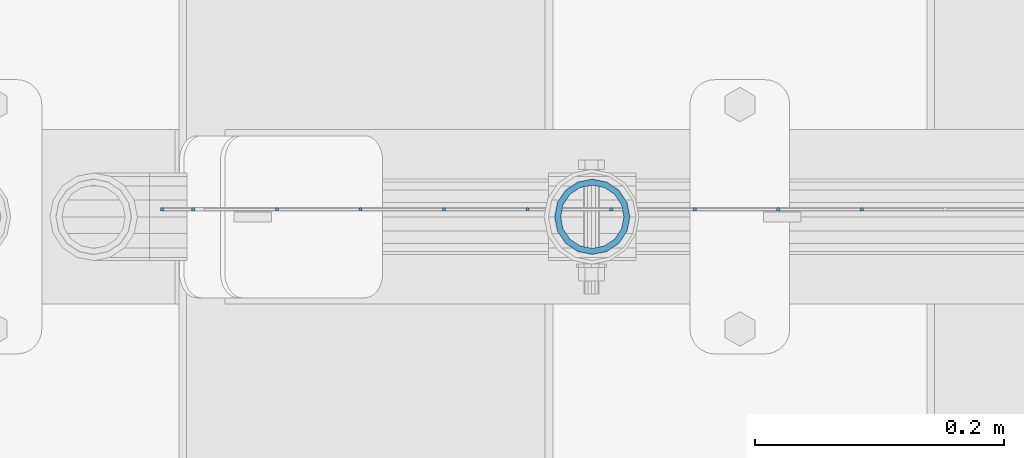
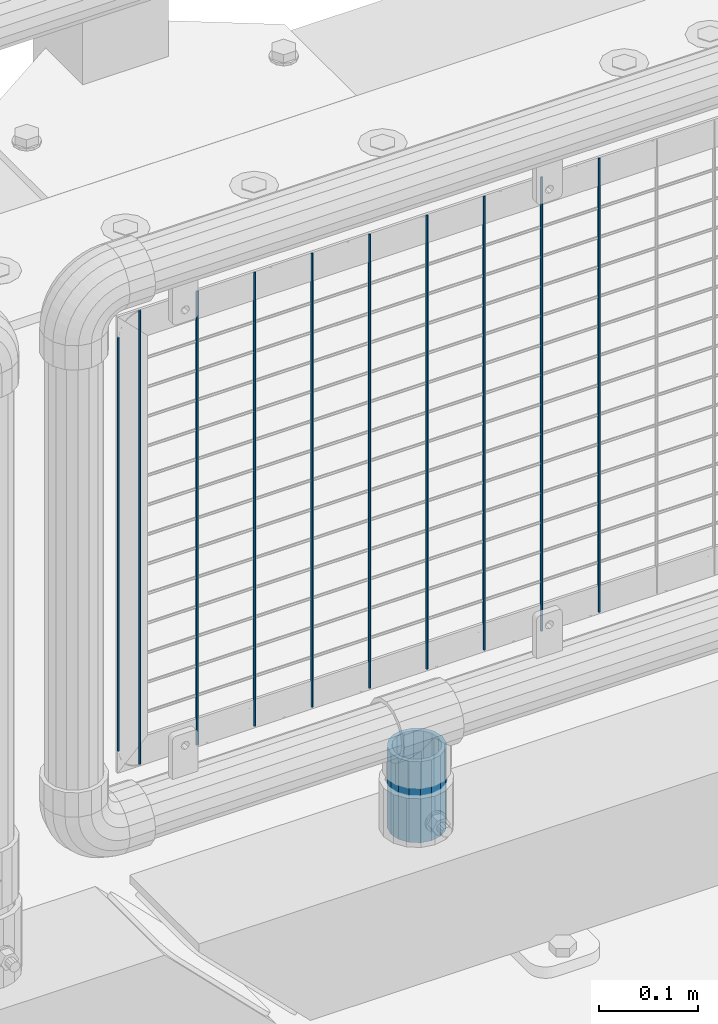
# One storey, part 92 of 219: 11 columns.
"""IFC2X3 building model written with IfcOpenShell, lengths in millimetres."""

from ifc_helpers import new_model, si_unit, frame, origin_with_axes, place, context, subcontext, project, spatial, faceted_brep, material, type_object, element, save


model = new_model("IFC2X3")

# Units and contexts
model_context = context("Model", 3, precision=1e-05, world=origin_with_axes())
body_context = subcontext(model_context, "Body", "Model", "MODEL_VIEW")
ifc_project = project(units=[si_unit("LENGTHUNIT", "METRE", prefix="MILLI"), si_unit("AREAUNIT", "SQUARE_METRE"), si_unit("VOLUMEUNIT", "CUBIC_METRE"), si_unit("MASSUNIT", "GRAM", prefix="KILO"), si_unit("TIMEUNIT", "SECOND"), si_unit("PLANEANGLEUNIT", "RADIAN"), si_unit("SOLIDANGLEUNIT", "STERADIAN"), si_unit("THERMODYNAMICTEMPERATUREUNIT", "DEGREE_CELSIUS"), si_unit("LUMINOUSINTENSITYUNIT", "LUMEN")], contexts=[model_context])

# Site, building, storey
site_placement = place(None, origin_with_axes())
site = spatial("IfcSite", under=ifc_project, at=site_placement, CompositionType="ELEMENT")
building_placement = place(site_placement, origin_with_axes())
building = spatial("IfcBuilding", under=site, at=building_placement, Name="Standard", CompositionType="ELEMENT")
storey_placement = place(building_placement, origin_with_axes())
storey = spatial("IfcBuildingStorey", under=building, at=storey_placement, Name="Undefined", CompositionType="ELEMENT", Elevation=0.0)

# Columns
ifc_material_1 = material()
column_type_1 = type_object("IfcColumnType", PredefinedType="NOTDEFINED")
column_1_placement = place(storey_placement, frame((12731.61, 31664.5, 168.02), z_axis=(-1.0, 0.0, 0.0), x_axis=(0.0, 0.0, 1.0)))
element("IfcColumn", 1, at=column_1_placement, inside=storey, type_object=column_type_1, material=ifc_material_1, context=body_context, shape_type="Brep", body=[
    faceted_brep([(0.0, -25.3499999999985, 0.0), (0.0, -23.4203461491597, 9.70102501045585), (100.0, -23.4203461491597, 9.70102501045585), (100.0, -25.3499999999985, 0.0), (0.0, -17.9251569030785, 17.9251569030785), (100.0, -17.9251569030785, 17.9251569030785), (0.0, -9.70102501045403, 23.4203461491616), (100.0, -9.70102501045403, 23.4203461491616), (0.0, 0.0, 25.3500000000004), (100.0, 0.0, 25.3500000000004), (0.0, 9.70102501045403, 23.4203461491616), (100.0, 9.70102501045403, 23.4203461491616), (0.0, 17.9251569030785, 17.9251569030785), (100.0, 17.9251569030785, 17.9251569030785), (0.0, 23.4203461491597, 9.70102501045585), (100.0, 23.4203461491597, 9.70102501045585), (0.0, 25.3499999999985, 0.0), (100.0, 25.3499999999985, 0.0), (0.0, 23.4203461491597, -9.70102501045585), (100.0, 23.4203461491597, -9.70102501045585), (0.0, 17.9251569030785, -17.9251569030785), (100.0, 17.9251569030785, -17.9251569030785), (0.0, 9.70102501045403, -23.4203461491616), (100.0, 9.70102501045403, -23.4203461491616), (0.0, 0.0, -25.3500000000004), (100.0, 0.0, -25.3500000000004), (0.0, -9.70102501045403, -23.4203461491616), (100.0, -9.70102501045403, -23.4203461491616), (0.0, -17.9251569030785, -17.9251569030785), (100.0, -17.9251569030785, -17.9251569030785), (0.0, -23.4203461491597, -9.70102501045585), (100.0, -23.4203461491597, -9.70102501045585), (0.0, -30.1500000000015, 0.0), (0.0, -27.8549679052157, -11.5379054858076), (100.0, -27.8549679052157, -11.5379054858076), (100.0, -30.1500000000015, 0.0), (0.0, -21.3192694527752, -21.3192694527752), (100.0, -21.3192694527752, -21.3192694527752), (0.0, -11.5379054858058, -27.8549679052157), (100.0, -11.5379054858058, -27.8549679052157), (0.0, 0.0, -30.1499999999996), (100.0, 0.0, -30.1499999999996), (0.0, 11.5379054858058, -27.8549679052157), (100.0, 11.5379054858058, -27.8549679052157), (0.0, 21.3192694527752, -21.3192694527752), (100.0, 21.3192694527752, -21.3192694527752), (0.0, 27.8549679052157, -11.5379054858076), (100.0, 27.8549679052157, -11.5379054858076), (0.0, 30.1500000000015, 0.0), (100.0, 30.1500000000015, 0.0), (0.0, 27.8549679052157, 11.5379054858076), (100.0, 27.8549679052157, 11.5379054858076), (0.0, 21.3192694527752, 21.3192694527752), (100.0, 21.3192694527752, 21.3192694527752), (0.0, 11.5379054858058, 27.8549679052157), (100.0, 11.5379054858058, 27.8549679052157), (0.0, 0.0, 30.1499999999996), (100.0, 0.0, 30.1499999999996), (0.0, -11.5379054858058, 27.8549679052157), (100.0, -11.5379054858058, 27.8549679052157), (0.0, -21.3192694527752, 21.3192694527752), (100.0, -21.3192694527752, 21.3192694527752), (0.0, -27.8549679052157, 11.5379054858076), (100.0, -27.8549679052157, 11.5379054858076)], [[[0, 1, 2, 3]], [[1, 4, 5, 2]], [[4, 6, 7, 5]], [[6, 8, 9, 7]], [[8, 10, 11, 9]], [[10, 12, 13, 11]], [[12, 14, 15, 13]], [[14, 16, 17, 15]], [[16, 18, 19, 17]], [[18, 20, 21, 19]], [[20, 22, 23, 21]], [[22, 24, 25, 23]], [[24, 26, 27, 25]], [[26, 28, 29, 27]], [[28, 30, 31, 29]], [[30, 0, 3, 31]], [[32, 33, 34, 35]], [[33, 36, 37, 34]], [[36, 38, 39, 37]], [[38, 40, 41, 39]], [[40, 42, 43, 41]], [[42, 44, 45, 43]], [[44, 46, 47, 45]], [[46, 48, 49, 47]], [[48, 50, 51, 49]], [[50, 52, 53, 51]], [[52, 54, 55, 53]], [[54, 56, 57, 55]], [[56, 58, 59, 57]], [[58, 60, 61, 59]], [[60, 62, 63, 61]], [[62, 32, 35, 63]], [[37, 39, 41, 43, 45, 47, 49, 51, 53, 55, 57, 59, 61, 63, 35, 34], [5, 7, 9, 11, 13, 15, 17, 19, 21, 23, 25, 27, 29, 31, 3, 2]], [[62, 60, 58, 56, 54, 52, 50, 48, 46, 44, 42, 40, 38, 36, 33, 32], [30, 28, 26, 24, 22, 20, 18, 16, 14, 12, 10, 8, 6, 4, 1, 0]]]),
])
ifc_material_2 = material(Name="Misc_Undefined")
column_type_2 = type_object("IfcColumnType", Name="D3", PredefinedType="NOTDEFINED")
for number, where, z_axis, x_axis in (
    (2, (12947.8340000001, 31670.4998693538, 353.02), (-1.0, 0.0, 0.0), (0.0, 0.0, 1.0)),
    (3, (12746.7500000001, 31670.4999119802, 353.02), (-1.0, 0.0, 0.0), (0.0, 0.0, 1.0)),
    (4, (12679.7220000001, 31670.499926189, 353.02), (-1.0, 0.0, 0.0), (0.0, 0.0, 1.0)),
    (5, (12612.6940000001, 31670.4999403979, 353.02), (-1.0, 0.0, 0.0), (0.0, 0.0, 1.0)),
    (6, (12813.7780000001, 31670.4998977714, 353.02), (-1.0, 0.0, 0.0), (0.0, 0.0, 1.0)),
    (7, (12545.666, 31670.4999546067, 353.02), (-1.0, 0.0, 0.0), (0.0, 0.0, 1.0)),
    (8, (12880.8060000001, 31670.4998835626, 353.02), (-1.0, 0.0, 0.0), (0.0, 0.0, 1.0)),
    (9, (12478.638, 31670.4999688155, 353.02), (-1.0, 0.0, 0.0), (0.0, 0.0, 1.0)),
):
    element("IfcColumn", number, at=place(storey_placement, frame(where, z_axis=z_axis, x_axis=x_axis)), inside=storey, type_object=column_type_2, material=ifc_material_2, ObjectType="D3", context=body_context, shape_type="Brep", body=[
        faceted_brep([(0.0, -1.5, -5.6843418860808e-14), (0.0, -0.75, -1.29903810567669), (560.0, -0.75, -1.29903810567703), (560.0, -1.5, 0.0), (0.0, 0.75, -1.29903810567669), (560.0, 0.75, -1.29903810567703), (0.0, 1.5, -5.6843418860808e-14), (560.0, 1.5, 0.0), (0.0, 0.75, 1.29903810567669), (560.0, 0.75, 1.29903810567703), (0.0, -0.75, 1.29903810567669), (560.0, -0.75, 1.29903810567703)], [[[0, 1, 2, 3]], [[1, 4, 5, 2]], [[4, 6, 7, 5]], [[6, 8, 9, 7]], [[8, 10, 11, 9]], [[10, 0, 3, 11]], [[5, 7, 9, 11, 3, 2]], [[10, 8, 6, 4, 1, 0]]]),
    ])
column_2_placement = place(storey_placement, frame((12386.61, 31670.4999883292, 378.02), z_axis=(-1.0, 0.0, 0.0), x_axis=(0.0, 0.0, 1.0)))
element("IfcColumn", 10, at=column_2_placement, inside=storey, type_object=column_type_2, material=ifc_material_2, ObjectType="D3", context=body_context, shape_type="Brep", body=[
    faceted_brep([(0.0, -1.5, -5.6843418860808e-14), (0.0, -0.75, -1.29903810567669), (510.0, -0.75, -1.29903810567703), (510.0, -1.5, 0.0), (0.0, 0.75, -1.29903810567669), (510.0, 0.75, -1.29903810567703), (0.0, 1.5, -5.6843418860808e-14), (510.0, 1.5, 0.0), (0.0, 0.75, 1.29903810567669), (510.0, 0.75, 1.29903810567703), (0.0, -0.75, 1.29903810567669), (510.0, -0.75, 1.29903810567703)], [[[0, 1, 2, 3]], [[1, 4, 5, 2]], [[4, 6, 7, 5]], [[6, 8, 9, 7]], [[8, 10, 11, 9]], [[10, 0, 3, 11]], [[5, 7, 9, 11, 3, 2]], [[10, 8, 6, 4, 1, 0]]]),
])
column_3_placement = place(storey_placement, frame((12411.61, 31670.4999830243, 353.02), z_axis=(-1.0, 0.0, 0.0), x_axis=(0.0, 0.0, 1.0)))
element("IfcColumn", 11, at=column_3_placement, inside=storey, type_object=column_type_2, material=ifc_material_2, ObjectType="D3", context=body_context, shape_type="Brep", body=[
    faceted_brep([(0.0, -1.5, -5.6843418860808e-14), (0.0, -0.75, -1.29903810567669), (560.0, -0.75, -1.29903810567703), (560.0, -1.5, 0.0), (0.0, 0.75, -1.29903810567669), (560.0, 0.75, -1.29903810567703), (0.0, 1.5, -5.6843418860808e-14), (560.0, 1.5, 0.0), (0.0, 0.75, 1.29903810567669), (560.0, 0.75, 1.29903810567703), (0.0, -0.75, 1.29903810567669), (560.0, -0.75, 1.29903810567703)], [[[0, 1, 2, 3]], [[1, 4, 5, 2]], [[4, 6, 7, 5]], [[6, 8, 9, 7]], [[8, 10, 11, 9]], [[10, 0, 3, 11]], [[5, 7, 9, 11, 3, 2]], [[10, 8, 6, 4, 1, 0]]]),
])

save(model, "model.ifc")
